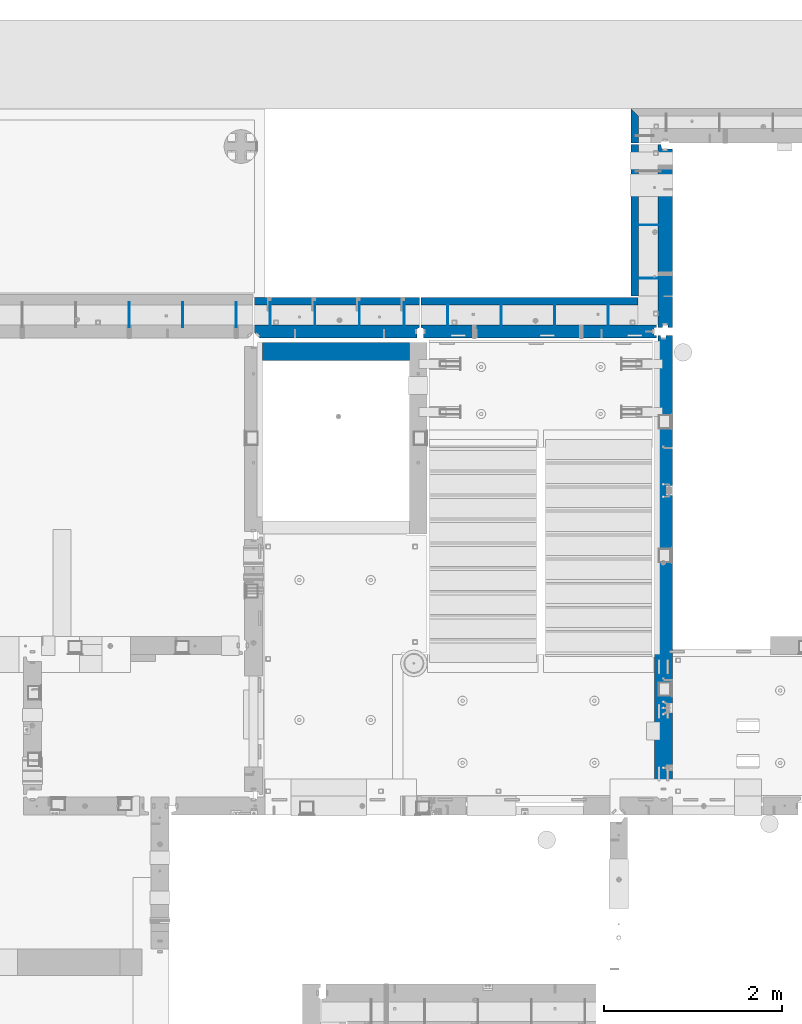
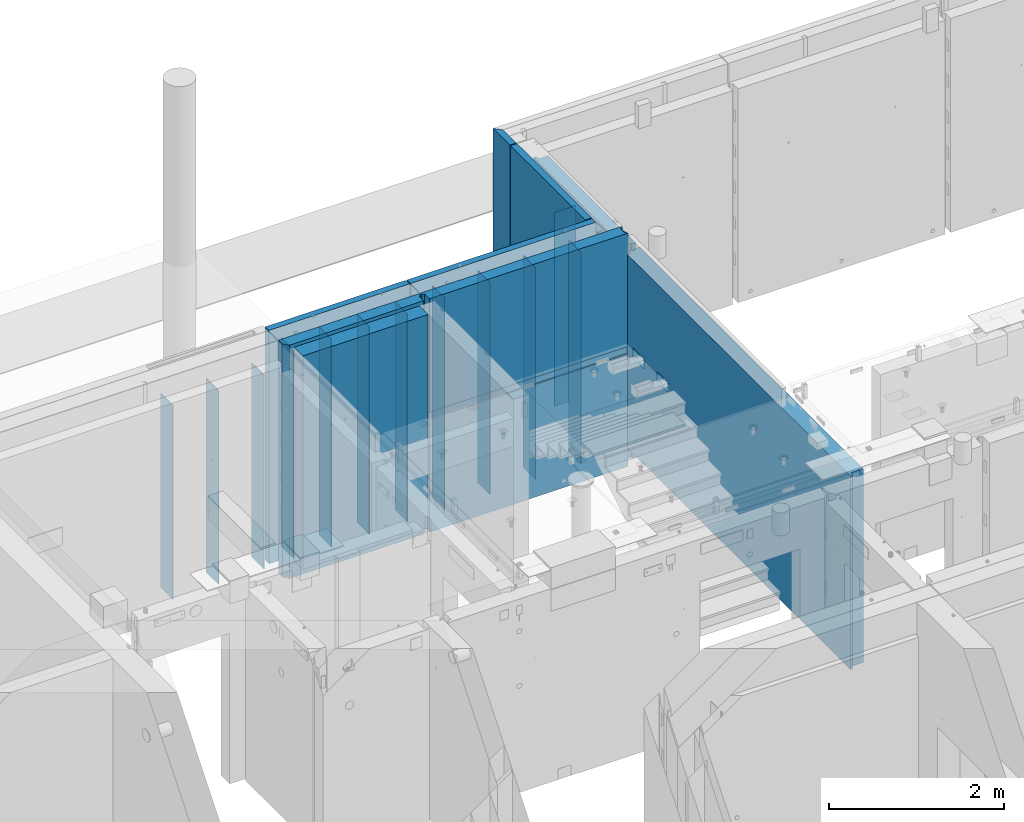
# One storey, part 176 of 264: 22 walls, 7 elements without a shape of their own.
"""IFC2X3 building model written with IfcOpenShell, lengths in millimetres."""

from ifc_helpers import new_model, si_unit, frame, origin_with_axes, place, context, subcontext, project, spatial, faceted_brep, material, type_object, element, aggregate, save


model = new_model("IFC2X3")

# Units and contexts
model_context = context("Model", 3, precision=1e-05, world=origin_with_axes())
body_context = subcontext(model_context, "Body", "Model", "MODEL_VIEW")
ifc_project = project(units=[si_unit("LENGTHUNIT", "METRE", prefix="MILLI"), si_unit("AREAUNIT", "SQUARE_METRE"), si_unit("VOLUMEUNIT", "CUBIC_METRE"), si_unit("MASSUNIT", "GRAM", prefix="KILO"), si_unit("TIMEUNIT", "SECOND"), si_unit("PLANEANGLEUNIT", "RADIAN"), si_unit("SOLIDANGLEUNIT", "STERADIAN"), si_unit("THERMODYNAMICTEMPERATUREUNIT", "DEGREE_CELSIUS"), si_unit("LUMINOUSINTENSITYUNIT", "LUMEN")], contexts=[model_context])

# Site, building, storey
site_placement = place(None, origin_with_axes())
site = spatial("IfcSite", under=ifc_project, at=site_placement, CompositionType="ELEMENT")
building_placement = place(site_placement, origin_with_axes())
building = spatial("IfcBuilding", under=site, at=building_placement, CompositionType="ELEMENT")
storey_placement = place(building_placement, origin_with_axes())
storey = spatial("IfcBuildingStorey", under=building, at=storey_placement, Name="K", CompositionType="ELEMENT", Elevation=0.0)

# Assembly, wall
assembly_1_placement = place(storey_placement, origin_with_axes())
assembly_1 = element("IfcElementAssembly", 1, at=assembly_1_placement, inside=storey, AssemblyPlace="NOTDEFINED", PredefinedType="REINFORCEMENT_UNIT")
ifc_material_1 = material(Name="CONCRETE/C25/30")
wall_type_1 = type_object("IfcWallType", PredefinedType="NOTDEFINED")
wall_1_placement = place(assembly_1_placement, frame((17809.9999105288, 20280.0000293051, 80242.5), z_axis=(0.0, 0.0, 1.0), x_axis=(1.0, 0.0, 0.0)))
wall_1 = element("IfcWall", 2, at=wall_1_placement, type_object=wall_type_1, material=ifc_material_1, context=body_context, shape_type="Brep", body=[
    faceted_brep([(0.0, 100.0, -1487.5), (0.0, 100.0, 1487.5), (1649.99977111816, 100.0, 1487.5), (1649.99977111816, 100.0, -1487.5), (0.0, -100.0, 1487.5), (1649.99977111816, -100.0, 1487.5), (0.0, -100.0, -1487.5), (1649.99977111816, -100.0, -1487.5)], [[[0, 1, 2, 3]], [[1, 4, 5, 2]], [[4, 6, 7, 5]], [[6, 0, 3, 7]], [[5, 7, 3, 2]], [[6, 4, 1, 0]]]),
])
aggregate(assembly_1, [wall_1])

# Assembly, walls
assembly_2_placement = place(storey_placement, origin_with_axes())
assembly_2 = element("IfcElementAssembly", 3, at=assembly_2_placement, inside=storey, AssemblyPlace="NOTDEFINED", PredefinedType="REINFORCEMENT_UNIT")
ifc_material_2 = material(Name="Undefined")
wall_type_2 = type_object("IfcWallType", PredefinedType="NOTDEFINED")
wall_2_placement = place(assembly_2_placement, frame((22280.0033032291, 21699.9956621903, 79990.0), z_axis=(0.0, 0.0, 1.0), x_axis=(-1.0, 3.00000001838171e-08, 0.0)))
wall_2 = element("IfcWall", 4, at=wall_2_placement, type_object=wall_type_2, material=ifc_material_2, Name="(PD)", context=body_context, shape_type="Brep", body=[
    faceted_brep([(0.0, 5.0, -1350.0), (0.0, 5.0, 1350.0), (280.0, 5.0, 1350.0), (280.0, 5.0, -1350.0), (0.0, -5.0, 1350.0), (280.0, -5.0, 1350.0), (0.0, -5.0, -1350.0), (280.0, -5.0, -1350.0)], [[[0, 1, 2, 3]], [[1, 4, 5, 2]], [[4, 6, 7, 5]], [[6, 0, 3, 7]], [[5, 7, 3, 2]], [[6, 4, 1, 0]]]),
])
wall_3_placement = place(assembly_2_placement, frame((22280.0033032291, 21099.9956621903, 79990.0), z_axis=(0.0, 0.0, 1.0), x_axis=(-1.0, 3.00000001838171e-08, 0.0)))
wall_3 = element("IfcWall", 5, at=wall_3_placement, type_object=wall_type_2, material=ifc_material_2, Name="(PD)", context=body_context, shape_type="Brep", body=[
    faceted_brep([(0.0, 5.0, -1350.0), (0.0, 5.0, 1350.0), (280.0, 5.0, 1350.0), (280.0, 5.0, -1350.0), (0.0, -5.0, 1350.0), (280.0, -5.0, 1350.0), (0.0, -5.0, -1350.0), (280.0, -5.0, -1350.0)], [[[0, 1, 2, 3]], [[1, 4, 5, 2]], [[4, 6, 7, 5]], [[6, 0, 3, 7]], [[5, 7, 3, 2]], [[6, 4, 1, 0]]]),
])

assembly_3_placement = place(storey_placement, origin_with_axes())
assembly_3 = element("IfcElementAssembly", 6, at=assembly_3_placement, inside=storey, AssemblyPlace="NOTDEFINED", PredefinedType="REINFORCEMENT_UNIT")
wall_4_placement = place(assembly_3_placement, frame((17515.0002441406, 20549.9951872276, 79990.0), z_axis=(0.0, 0.0, 1.0), x_axis=(0.0, 1.0, 0.0)))
wall_4 = element("IfcWall", 7, at=wall_4_placement, type_object=wall_type_2, material=ifc_material_2, Name="(PD)", context=body_context, shape_type="Brep", body=[
    faceted_brep([(0.0, 5.0, -1350.0), (0.0, 5.0, 1350.0), (280.0, 5.0, 1350.0), (280.0, 5.0, -1350.0), (0.0, -5.0, 1350.0), (280.0, -5.0, 1350.0), (0.0, -5.0, -1350.0), (280.0, -5.0, -1350.0)], [[[0, 1, 2, 3]], [[1, 4, 5, 2]], [[4, 6, 7, 5]], [[6, 0, 3, 7]], [[5, 7, 3, 2]], [[6, 4, 1, 0]]]),
])
wall_5_placement = place(assembly_3_placement, frame((16915.0002441406, 20549.9951872276, 79990.0), z_axis=(0.0, 0.0, 1.0), x_axis=(0.0, 1.0, 0.0)))
wall_5 = element("IfcWall", 8, at=wall_5_placement, type_object=wall_type_2, material=ifc_material_2, Name="(PD)", context=body_context, shape_type="Brep", body=[
    faceted_brep([(0.0, 5.0, -1350.0), (0.0, 5.0, 1350.0), (280.0, 5.0, 1350.0), (280.0, 5.0, -1350.0), (0.0, -5.0, 1350.0), (280.0, -5.0, 1350.0), (0.0, -5.0, -1350.0), (280.0, -5.0, -1350.0)], [[[0, 1, 2, 3]], [[1, 4, 5, 2]], [[4, 6, 7, 5]], [[6, 0, 3, 7]], [[5, 7, 3, 2]], [[6, 4, 1, 0]]]),
])
wall_6_placement = place(assembly_3_placement, frame((16315.0002441406, 20549.9951872276, 79990.0), z_axis=(0.0, 0.0, 1.0), x_axis=(0.0, 1.0, 0.0)))
wall_6 = element("IfcWall", 9, at=wall_6_placement, type_object=wall_type_2, material=ifc_material_2, Name="(PD)", context=body_context, shape_type="Brep", body=[
    faceted_brep([(0.0, 5.0, -1350.0), (0.0, 5.0, 1350.0), (280.0, 5.0, 1350.0), (280.0, 5.0, -1350.0), (0.0, -5.0, 1350.0), (280.0, -5.0, 1350.0), (0.0, -5.0, -1350.0), (280.0, -5.0, -1350.0)], [[[0, 1, 2, 3]], [[1, 4, 5, 2]], [[4, 6, 7, 5]], [[6, 0, 3, 7]], [[5, 7, 3, 2]], [[6, 4, 1, 0]]]),
])
aggregate(assembly_3, [wall_4, wall_5, wall_6])

assembly_4_placement = place(storey_placement, origin_with_axes())
assembly_4 = element("IfcElementAssembly", 10, at=assembly_4_placement, inside=storey, AssemblyPlace="NOTDEFINED", PredefinedType="REINFORCEMENT_UNIT")
wall_type_3 = type_object("IfcWallType", PredefinedType="NOTDEFINED")
wall_7_placement = place(assembly_4_placement, frame((21690.0002441406, 20549.9951872276, 80115.0), z_axis=(0.0, 0.0, 1.0), x_axis=(0.0, 1.0, 0.0)))
wall_7 = element("IfcWall", 11, at=wall_7_placement, type_object=wall_type_3, material=ifc_material_2, Name="(PD)", context=body_context, shape_type="Brep", body=[
    faceted_brep([(0.0, 5.0, -1475.0), (0.0, 5.0, 1475.0), (280.0, 5.0, 1475.0), (280.0, 5.0, -1475.0), (0.0, -5.0, 1475.0), (280.0, -5.0, 1475.0), (0.0, -5.0, -1475.0), (280.0, -5.0, -1475.0)], [[[0, 1, 2, 3]], [[1, 4, 5, 2]], [[4, 6, 7, 5]], [[6, 0, 3, 7]], [[5, 7, 3, 2]], [[6, 4, 1, 0]]]),
])
wall_8_placement = place(assembly_4_placement, frame((21090.0002441406, 20549.9951872276, 80115.0), z_axis=(0.0, 0.0, 1.0), x_axis=(0.0, 1.0, 0.0)))
wall_8 = element("IfcWall", 12, at=wall_8_placement, type_object=wall_type_3, material=ifc_material_2, Name="(PD)", context=body_context, shape_type="Brep", body=[
    faceted_brep([(0.0, 5.0, -1475.0), (0.0, 5.0, 1475.0), (280.0, 5.0, 1475.0), (280.0, 5.0, -1475.0), (0.0, -5.0, 1475.0), (280.0, -5.0, 1475.0), (0.0, -5.0, -1475.0), (280.0, -5.0, -1475.0)], [[[0, 1, 2, 3]], [[1, 4, 5, 2]], [[4, 6, 7, 5]], [[6, 0, 3, 7]], [[5, 7, 3, 2]], [[6, 4, 1, 0]]]),
])
wall_9_placement = place(assembly_4_placement, frame((20490.0002441406, 20549.9951872276, 80115.0), z_axis=(0.0, 0.0, 1.0), x_axis=(0.0, 1.0, 0.0)))
wall_9 = element("IfcWall", 13, at=wall_9_placement, type_object=wall_type_3, material=ifc_material_2, Name="(PD)", context=body_context, shape_type="Brep", body=[
    faceted_brep([(0.0, 5.0, -1475.0), (0.0, 5.0, 1475.0), (280.0, 5.0, 1475.0), (280.0, 5.0, -1475.0), (0.0, -5.0, 1475.0), (280.0, -5.0, 1475.0), (0.0, -5.0, -1475.0), (280.0, -5.0, -1475.0)], [[[0, 1, 2, 3]], [[1, 4, 5, 2]], [[4, 6, 7, 5]], [[6, 0, 3, 7]], [[5, 7, 3, 2]], [[6, 4, 1, 0]]]),
])
wall_10_placement = place(assembly_4_placement, frame((19890.0002441406, 20549.9951872276, 80115.0), z_axis=(0.0, 0.0, 1.0), x_axis=(0.0, 1.0, 0.0)))
wall_10 = element("IfcWall", 14, at=wall_10_placement, type_object=wall_type_3, material=ifc_material_2, Name="(PD)", context=body_context, shape_type="Brep", body=[
    faceted_brep([(0.0, 5.0, -1475.0), (0.0, 5.0, 1475.0), (280.0, 5.0, 1475.0), (280.0, 5.0, -1475.0), (0.0, -5.0, 1475.0), (280.0, -5.0, 1475.0), (0.0, -5.0, -1475.0), (280.0, -5.0, -1475.0)], [[[0, 1, 2, 3]], [[1, 4, 5, 2]], [[4, 6, 7, 5]], [[6, 0, 3, 7]], [[5, 7, 3, 2]], [[6, 4, 1, 0]]]),
])

assembly_5_placement = place(storey_placement, origin_with_axes())
assembly_5 = element("IfcElementAssembly", 15, at=assembly_5_placement, inside=storey, AssemblyPlace="NOTDEFINED", PredefinedType="REINFORCEMENT_UNIT")
wall_type_4 = type_object("IfcWallType", PredefinedType="NOTDEFINED")
wall_11_placement = place(assembly_5_placement, frame((19400.0002441406, 20549.9951872276, 80090.0), z_axis=(0.0, 0.0, 1.0), x_axis=(0.0, 1.0, 0.0)))
wall_11 = element("IfcWall", 16, at=wall_11_placement, type_object=wall_type_4, material=ifc_material_2, Name="(PD)", context=body_context, shape_type="Brep", body=[
    faceted_brep([(0.0, 5.0, -1450.0), (0.0, 5.0, 1450.0), (280.0, 5.0, 1450.0), (280.0, 5.0, -1450.0), (0.0, -5.0, 1450.0), (280.0, -5.0, 1450.0), (0.0, -5.0, -1450.0), (280.0, -5.0, -1450.0)], [[[0, 1, 2, 3]], [[1, 4, 5, 2]], [[4, 6, 7, 5]], [[6, 0, 3, 7]], [[5, 7, 3, 2]], [[6, 4, 1, 0]]]),
])
wall_12_placement = place(assembly_5_placement, frame((18900.0002441406, 20549.9951872276, 80090.0), z_axis=(0.0, 0.0, 1.0), x_axis=(0.0, 1.0, 0.0)))
wall_12 = element("IfcWall", 17, at=wall_12_placement, type_object=wall_type_4, material=ifc_material_2, Name="(PD)", context=body_context, shape_type="Brep", body=[
    faceted_brep([(0.0, 5.0, -1450.0), (0.0, 5.0, 1450.0), (280.0, 5.0, 1450.0), (280.0, 5.0, -1450.0), (0.0, -5.0, 1450.0), (280.0, -5.0, 1450.0), (0.0, -5.0, -1450.0), (280.0, -5.0, -1450.0)], [[[0, 1, 2, 3]], [[1, 4, 5, 2]], [[4, 6, 7, 5]], [[6, 0, 3, 7]], [[5, 7, 3, 2]], [[6, 4, 1, 0]]]),
])
wall_13_placement = place(assembly_5_placement, frame((18400.0002441406, 20549.9951872276, 80090.0), z_axis=(0.0, 0.0, 1.0), x_axis=(0.0, 1.0, 0.0)))
wall_13 = element("IfcWall", 18, at=wall_13_placement, type_object=wall_type_4, material=ifc_material_2, Name="(PD)", context=body_context, shape_type="Brep", body=[
    faceted_brep([(0.0, 5.0, -1450.0), (0.0, 5.0, 1450.0), (280.0, 5.0, 1450.0), (280.0, 5.0, -1450.0), (0.0, -5.0, 1450.0), (280.0, -5.0, 1450.0), (0.0, -5.0, -1450.0), (280.0, -5.0, -1450.0)], [[[0, 1, 2, 3]], [[1, 4, 5, 2]], [[4, 6, 7, 5]], [[6, 0, 3, 7]], [[5, 7, 3, 2]], [[6, 4, 1, 0]]]),
])
wall_14_placement = place(assembly_5_placement, frame((17900.0002441406, 20549.9951872276, 80110.0), z_axis=(0.0, 0.0, 1.0), x_axis=(0.0, 1.0, 0.0)))
wall_14 = element("IfcWall", 19, at=wall_14_placement, type_object=wall_type_4, material=ifc_material_2, Name="(PD)", context=body_context, shape_type="Brep", body=[
    faceted_brep([(0.0, 5.0, -1450.0), (0.0, 5.0, 1450.0), (280.0, 5.0, 1450.0), (280.0, 5.0, -1450.0), (0.0, -5.0, 1450.0), (280.0, -5.0, 1450.0), (0.0, -5.0, -1450.0), (280.0, -5.0, -1450.0)], [[[0, 1, 2, 3]], [[1, 4, 5, 2]], [[4, 6, 7, 5]], [[6, 0, 3, 7]], [[5, 7, 3, 2]], [[6, 4, 1, 0]]]),
])

# Assembly, wall
assembly_6_placement = place(storey_placement, origin_with_axes())
assembly_6 = element("IfcElementAssembly", 20, at=assembly_6_placement, inside=storey, AssemblyPlace="NOTDEFINED", PredefinedType="REINFORCEMENT_UNIT")
ifc_material_3 = material(Name="CONCRETE/C30/37")
wall_type_5 = type_object("IfcWallType", PredefinedType="NOTDEFINED")
wall_15_placement = place(assembly_6_placement, frame((21987.4994055291, 23005.0, 80115.0), z_axis=(0.0, 0.0, 1.0), x_axis=(0.0, -1.0, 0.0)))
wall_15 = element("IfcWall", 21, at=wall_15_placement, type_object=wall_type_5, material=ifc_material_3, context=body_context, shape_type="Brep", body=[
    faceted_brep([(385.0, -42.5, 1625.0), (385.0, -42.5, -1625.0), (385.0, 42.5, -1625.0), (385.0, 42.5, 1625.0), (85.0, 42.5, 1625.0), (3.63797880709171e-12, -42.4999999999964, 1625.0), (3.63797880709171e-12, -42.4999999999964, -1625.0), (85.0, 42.5, -1625.0)], [[[0, 1, 2, 3]], [[0, 3, 4, 5]], [[1, 0, 5, 6]], [[2, 1, 6, 7]], [[3, 2, 7, 4]], [[6, 5, 4, 7]]]),
])
aggregate(assembly_6, [wall_15])

# Wall
wall_16_placement = place(assembly_2_placement, frame((21987.4994055291, 20899.9994219008, 80115.0), z_axis=(0.0, 0.0, 1.0), x_axis=(0.0, 1.0, 0.0)))
wall_16 = element("IfcWall", 22, at=wall_16_placement, type_object=wall_type_5, material=ifc_material_3, context=body_context, shape_type="Brep", body=[
    faceted_brep([(1366.8658789863, -42.5, -742.815116744532), (1366.8658789863, 42.5, -742.815116744532), (1357.62099845137, 42.5, -769.235467389692), (1357.62099845137, -42.5, -769.235467389692), (1342.72882527207, 42.5, -792.936225232348), (1342.72882527207, -42.5, -792.936225232348), (1322.93611519591, 42.5, -812.728935308507), (1322.93611519591, -42.5, -812.728935308507), (1299.23535735326, 42.5, -827.621108487801), (1299.23535735326, -42.5, -827.621108487801), (1272.81500670811, 42.5, -836.865989022728), (1272.81500670811, -42.5, -836.865989022728), (1244.99988996357, 42.5, -840.0), (1244.99988996357, -42.5, -840.0), (1217.18477321903, 42.5, -836.865989022728), (1217.18477321903, -42.5, -836.865989022728), (1190.76442257387, 42.5, -827.621108487801), (1190.76442257387, -42.5, -827.621108487801), (1167.06366473123, 42.5, -812.728935308507), (1167.06366473123, -42.5, -812.728935308507), (1147.27095465507, 42.5, -792.936225232348), (1147.27095465507, -42.5, -792.936225232348), (1132.37878147577, 42.5, -769.235467389692), (1132.37878147577, -42.5, -769.235467389692), (1123.13390094084, 42.5, -742.815116744532), (1123.13390094084, -42.5, -742.815116744532), (1119.99988996357, 42.5, -715.0), (1119.99988996357, -42.5, -715.0), (1123.13390094084, 42.5, -687.184883255468), (1123.13390094084, -42.5, -687.184883255468), (1132.37878147577, 42.5, -660.764532610308), (1132.37878147577, -42.5, -660.764532610308), (1147.27095465507, 42.5, -637.063774767652), (1147.27095465507, -42.5, -637.063774767652), (1167.06366473123, 42.5, -617.271064691493), (1167.06366473123, -42.5, -617.271064691493), (1190.76442257387, 42.5, -602.378891512199), (1190.76442257387, -42.5, -602.378891512199), (1217.18477321903, 42.5, -593.134010977272), (1217.18477321903, -42.5, -593.134010977272), (1244.99988996357, 42.5, -590.0), (1244.99988996357, -42.5, -590.0), (1272.81500670811, 42.5, -593.134010977272), (1272.81500670811, -42.5, -593.134010977272), (1299.23535735326, 42.5, -602.378891512199), (1299.23535735326, -42.5, -602.378891512199), (1322.93611519591, 42.5, -617.271064691493), (1322.93611519591, -42.5, -617.271064691493), (1342.72882527207, 42.5, -637.063774767652), (1342.72882527207, -42.5, -637.063774767652), (1357.62099845137, 42.5, -660.764532610308), (1357.62099845137, -42.5, -660.764532610308), (1366.8658789863, 42.5, -687.184883255468), (1366.8658789863, -42.5, -687.184883255468), (1369.99988996357, 42.5, -715.0), (1369.99988996357, -42.5, -715.0), (0.0, 42.5000000000036, 1625.0), (3.63797880709171e-12, -42.4999999999964, 1625.0), (1705.00057809919, -42.5, 1625.0), (1705.00057809919, 42.5, 1625.0), (3.63797880709171e-12, -42.4999999999964, -1625.0), (0.0, 42.5000000000036, -1625.0), (1705.00057809919, 42.5, -1625.0), (1705.00057809919, -42.5, -1625.0), (1606.60395622092, -42.5, -765.0), (1590.71209396113, -42.5, -785.710678118659), (1570.00141584247, -42.5, -801.602540378444), (1545.88332035273, -42.5, -811.592582628902), (1520.00141584247, -42.5, -815.0), (1494.11951133222, -42.5, -811.592582628902), (1470.00141584247, -42.5, -801.602540378444), (1449.29073772382, -42.5, -785.710678118659), (1433.39887546403, -42.5, -765.0), (1423.40883321357, -42.5, -740.881904510257), (1420.00141584247, -42.5, -715.0), (1423.40883321357, -42.5, -689.118095489743), (1433.39887546403, -42.5, -665.0), (1449.29073772382, -42.5, -644.289321881341), (1470.00141584247, -42.5, -628.397459621556), (1494.11951133222, -42.5, -618.407417371098), (1520.00141584247, -42.5, -615.0), (1545.88332035273, -42.5, -618.407417371098), (1570.00141584247, -42.5, -628.397459621556), (1590.71209396113, -42.5, -644.289321881341), (1606.60395622092, -42.5, -665.0), (1616.59399847138, -42.5, -689.118095489743), (1620.00141584247, -42.5, -715.0), (1616.59399847138, -42.5, -740.881904510257), (1606.60395622092, 42.5, -665.0), (1616.59399847138, 42.5, -689.118095489743), (1590.71209396113, 42.5, -644.289321881341), (1570.00141584247, 42.5, -628.397459621556), (1545.88332035273, 42.5, -618.407417371098), (1520.00141584247, 42.5, -615.0), (1494.11951133222, 42.5, -618.407417371098), (1470.00141584247, 42.5, -628.397459621556), (1449.29073772382, 42.5, -644.289321881341), (1433.39887546403, 42.5, -665.0), (1423.40883321357, 42.5, -689.118095489743), (1420.00141584247, 42.5, -715.0), (1423.40883321357, 42.5, -740.881904510257), (1433.39887546403, 42.5, -765.0), (1449.29073772382, 42.5, -785.710678118659), (1470.00141584247, 42.5, -801.602540378444), (1494.11951133222, 42.5, -811.592582628902), (1520.00141584247, 42.5, -815.0), (1545.88332035273, 42.5, -811.592582628902), (1570.00141584247, 42.5, -801.602540378444), (1590.71209396113, 42.5, -785.710678118659), (1606.60395622092, 42.5, -765.0), (1616.59399847138, 42.5, -740.881904510257), (1620.00141584247, 42.5, -715.0)], [[[0, 1, 2, 3]], [[3, 2, 4, 5]], [[5, 4, 6, 7]], [[7, 6, 8, 9]], [[9, 8, 10, 11]], [[11, 10, 12, 13]], [[13, 12, 14, 15]], [[15, 14, 16, 17]], [[17, 16, 18, 19]], [[19, 18, 20, 21]], [[21, 20, 22, 23]], [[23, 22, 24, 25]], [[25, 24, 26, 27]], [[27, 26, 28, 29]], [[29, 28, 30, 31]], [[31, 30, 32, 33]], [[33, 32, 34, 35]], [[35, 34, 36, 37]], [[37, 36, 38, 39]], [[39, 38, 40, 41]], [[41, 40, 42, 43]], [[43, 42, 44, 45]], [[45, 44, 46, 47]], [[47, 46, 48, 49]], [[49, 48, 50, 51]], [[51, 50, 52, 53]], [[53, 52, 54, 55]], [[55, 54, 1, 0]], [[56, 57, 58, 59]], [[60, 57, 56, 61]], [[60, 61, 62, 63]], [[58, 63, 62, 59]], [[57, 60, 63, 58], [3, 5, 7, 9, 11, 13, 15, 17, 19, 21, 23, 25, 27, 29, 31, 33, 35, 37, 39, 41, 43, 45, 47, 49, 51, 53, 55, 0], [64, 65, 66, 67, 68, 69, 70, 71, 72, 73, 74, 75, 76, 77, 78, 79, 80, 81, 82, 83, 84, 85, 86, 87]], [[84, 88, 89, 85]], [[83, 90, 88, 84]], [[82, 91, 90, 83]], [[81, 92, 91, 82]], [[80, 93, 92, 81]], [[79, 94, 93, 80]], [[78, 95, 94, 79]], [[77, 96, 95, 78]], [[76, 97, 96, 77]], [[75, 98, 97, 76]], [[74, 99, 98, 75]], [[73, 100, 99, 74]], [[72, 101, 100, 73]], [[71, 102, 101, 72]], [[70, 103, 102, 71]], [[69, 104, 103, 70]], [[68, 105, 104, 69]], [[67, 106, 105, 68]], [[66, 107, 106, 67]], [[65, 108, 107, 66]], [[64, 109, 108, 65]], [[87, 110, 109, 64]], [[86, 111, 110, 87]], [[85, 89, 111, 86]], [[61, 56, 59, 62], [50, 48, 46, 44, 42, 40, 38, 36, 34, 32, 30, 28, 26, 24, 22, 20, 18, 16, 14, 12, 10, 8, 6, 4, 2, 1, 54, 52], [88, 90, 91, 92, 93, 94, 95, 96, 97, 98, 99, 100, 101, 102, 103, 104, 105, 106, 107, 108, 109, 110, 111, 89]]]),
])

wall_17_placement = place(assembly_4_placement, frame((19590.0015743464, 20842.5000000028, 80115.0), z_axis=(0.0, 0.0, 1.0), x_axis=(1.0, 0.0, 0.0)))
wall_17 = element("IfcWall", 23, at=wall_17_placement, type_object=wall_type_5, material=ifc_material_3, context=body_context, shape_type="Brep", body=[
    faceted_brep([(0.0, 42.5000000000036, -1625.0), (0.0, 42.5000000000036, 1625.0), (2434.99931653097, 42.4999999999964, 1625.0), (2434.99931653097, 42.4999999999964, -1625.0), (3.63797880709171e-12, -42.4999999999964, 1625.0), (2434.99931653097, -42.5000000000036, 1625.0), (3.63797880709171e-12, -42.4999999999964, -1625.0), (2434.99931653097, -42.5000000000036, -1625.0)], [[[0, 1, 2, 3]], [[1, 4, 5, 2]], [[4, 6, 7, 5]], [[6, 0, 3, 7]], [[5, 7, 3, 2]], [[6, 4, 1, 0]]]),
])

wall_18_placement = place(assembly_5_placement, frame((17720.0001611861, 20842.4999938629, 80115.0), z_axis=(0.0, 0.0, 1.0), x_axis=(1.0, 0.0, 0.0)))
wall_18 = element("IfcWall", 24, at=wall_18_placement, type_object=wall_type_5, material=ifc_material_3, context=body_context, shape_type="Brep", body=[
    faceted_brep([(-0.000187281060789246, 42.5000000000036, -1625.0), (-0.000187281060789246, 42.5000000000036, 1625.0), (1855.00146334826, 42.5000000000036, 1625.0), (1855.00146334826, 42.5000000000036, -1625.0), (-0.000135091060656123, -42.4999999999964, 1625.0), (1855.00146334826, -42.4999999999964, 1625.0), (-0.000135091060656123, -42.4999999999964, -1625.0), (1855.00146334826, -42.4999999999964, -1625.0)], [[[0, 1, 2, 3]], [[1, 4, 5, 2]], [[4, 6, 7, 5]], [[6, 0, 3, 7]], [[5, 7, 3, 2]], [[6, 4, 1, 0]]]),
])

wall_type_6 = type_object("IfcWallType", PredefinedType="NOTDEFINED")
wall_19_placement = place(assembly_2_placement, frame((22329.9994055291, 20579.9988438016, 79980.0), z_axis=(0.0, 0.0, 1.0), x_axis=(0.0, 1.0, 0.0)))
wall_19 = element("IfcWall", 25, at=wall_19_placement, type_object=wall_type_6, material=ifc_material_1, context=body_context, shape_type="Brep", body=[
    faceted_brep([(1936.59457657057, -80.0012033323073, -605.881904510257), (1936.59457657057, 80.0, -605.881904510257), (1926.60453432011, 80.0, -630.0), (1926.60453432011, -80.0012033323073, -630.0), (1910.71267206032, 80.0, -650.710678118659), (1910.71267206032, -80.0012033323073, -650.710678118659), (1890.00199394167, 80.0, -666.602540378444), (1890.00199394167, -80.0012033323073, -666.602540378444), (1865.88389845192, 80.0, -676.592582628902), (1865.88389845192, -80.0012033323073, -676.592582628902), (1840.00199394167, 80.0, -680.0), (1840.00199394167, -80.0012033323073, -680.0), (1814.12008943141, 80.0, -676.592582628902), (1814.12008943141, -80.0012033323073, -676.592582628902), (1790.00199394167, 80.0, -666.602540378444), (1790.00199394167, -80.0012033323073, -666.602540378444), (1769.29131582301, 80.0, -650.710678118659), (1769.29131582301, -80.0012033323073, -650.710678118659), (1753.39945356322, 80.0, -630.0), (1753.39945356322, -80.0012033323073, -630.0), (1743.40941131276, 80.0, -605.881904510257), (1743.40941131276, -80.0012033323073, -605.881904510257), (1740.00199394167, 80.0, -580.0), (1740.00199394167, -80.0012033323073, -580.0), (1743.40941131276, 80.0, -554.118095489743), (1743.40941131276, -80.0012033323073, -554.118095489743), (1753.39945356322, 80.0, -530.0), (1753.39945356322, -80.0012033323073, -530.0), (1769.29131582301, 80.0, -509.289321881341), (1769.29131582301, -80.0012033323073, -509.289321881341), (1790.00199394167, 80.0, -493.397459621556), (1790.00199394167, -80.0012033323073, -493.397459621556), (1814.12008943141, 80.0, -483.407417371098), (1814.12008943141, -80.0012033323073, -483.407417371098), (1840.00199394167, 80.0, -480.0), (1840.00199394167, -80.0012033323073, -480.0), (1865.88389845192, 80.0, -483.407417371098), (1865.88389845192, -80.0012033323073, -483.407417371098), (1890.00199394167, 80.0, -493.397459621556), (1890.00199394167, -80.0012033323073, -493.397459621556), (1910.71267206032, 80.0, -509.289321881341), (1910.71267206032, -80.0012033323073, -509.289321881341), (1926.60453432011, 80.0, -530.0), (1926.60453432011, -80.0012033323073, -530.0), (1936.59457657057, 80.0, -554.118095489743), (1936.59457657057, -80.0012033323073, -554.118095489743), (1940.00199394167, 80.0, -580.0), (1940.00199394167, -80.0012033323073, -580.0), (-4.99942190080765, 29.999405529139, 1490.0), (-4.99942190080765, 29.999405529139, -1265.0), (-4.99942190080765, -30.000594470861, -1265.0), (-4.99942190080765, -30.000594470861, 1490.0), (-29.9994219008076, 29.999405529139, 1490.0), (-29.9994219008076, 29.999405529139, -1265.0), (-29.9994219008076, 80.0, 1490.0), (-29.9994219008076, 80.0, -1490.0), (-29.9994219008076, 29.999405529139, -1490.0), (-4.99942190080765, 29.999405529139, -1490.0), (-4.99942190080765, -30.000594470861, -1490.0), (2025.00115619838, 80.0, -1490.0), (2025.00115619838, 50.0000000000036, -1490.0), (1975.00115619838, 37.0, -1490.0), (1975.00115619838, -80.0, -1490.0), (-29.9994219008076, -80.0, -1490.0), (-29.9994219008076, -30.000594470861, -1490.0), (-29.9994219008076, -30.000594470861, -1265.0), (-29.9994219008076, -80.0, 1490.0), (-29.9994219008076, -30.000594470861, 1490.0), (1975.00115619838, -80.0, 1490.0), (1975.00115619838, 37.0, 1490.0), (2025.00115619838, 50.0000000000036, 1490.0), (2025.00115619838, 80.0, 1490.0), (1677.62157655056, -80.0012033323073, -634.235467389692), (1662.72940337126, -80.0012033323073, -657.936225232348), (1642.9366932951, -80.0012033323073, -677.728935308507), (1619.23593545246, -80.0012033323073, -692.621108487801), (1592.8155848073, -80.0012033323073, -701.865989022728), (1565.00046806276, -80.0012033323073, -705.0), (1537.18535131822, -80.0012033323073, -701.865989022728), (1510.76500067307, -80.0012033323073, -692.621108487801), (1487.06424283042, -80.0012033323073, -677.728935308507), (1467.27153275426, -80.0012033323073, -657.936225232348), (1452.37935957496, -80.0012033323073, -634.235467389692), (1443.13447904003, -80.0012033323073, -607.815116744532), (1440.00046806276, -80.0012033323073, -580.0), (1443.13447904003, -80.0012033323073, -552.184883255468), (1452.37935957496, -80.0012033323073, -525.764532610308), (1467.27153275426, -80.0012033323073, -502.063774767652), (1487.06424283042, -80.0012033323073, -482.271064691493), (1510.76500067307, -80.0012033323073, -467.378891512199), (1537.18535131822, -80.0012033323073, -458.134010977272), (1565.00046806276, -80.0012033323073, -455.0), (1592.8155848073, -80.0012033323073, -458.134010977272), (1619.23593545246, -80.0012033323073, -467.378891512199), (1642.9366932951, -80.0012033323073, -482.271064691493), (1662.72940337126, -80.0012033323073, -502.063774767652), (1677.62157655056, -80.0012033323073, -525.764532610308), (1686.86645708549, -80.0012033323073, -552.184883255468), (1690.00046806276, -80.0012033323073, -580.0), (1686.86645708549, -80.0012033323073, -607.815116744532), (1677.62157655056, 80.0, -525.764532610308), (1686.86645708549, 80.0, -552.184883255468), (1662.72940337126, 80.0, -502.063774767652), (1642.9366932951, 80.0, -482.271064691493), (1619.23593545246, 80.0, -467.378891512199), (1592.8155848073, 80.0, -458.134010977272), (1565.00046806276, 80.0, -455.0), (1537.18535131822, 80.0, -458.134010977272), (1510.76500067307, 80.0, -467.378891512199), (1487.06424283042, 80.0, -482.271064691493), (1467.27153275426, 80.0, -502.063774767652), (1452.37935957496, 80.0, -525.764532610308), (1443.13447904003, 80.0, -552.184883255468), (1440.00046806276, 80.0, -580.0), (1443.13447904003, 80.0, -607.815116744532), (1452.37935957496, 80.0, -634.235467389692), (1467.27153275426, 80.0, -657.936225232348), (1487.06424283042, 80.0, -677.728935308507), (1510.76500067307, 80.0, -692.621108487801), (1537.18535131822, 80.0, -701.865989022728), (1565.00046806276, 80.0, -705.0), (1592.8155848073, 80.0, -701.865989022728), (1619.23593545246, 80.0, -692.621108487801), (1642.9366932951, 80.0, -677.728935308507), (1662.72940337126, 80.0, -657.936225232348), (1677.62157655056, 80.0, -634.235467389692), (1686.86645708549, 80.0, -607.815116744532), (1690.00046806276, 80.0, -580.0)], [[[0, 1, 2, 3]], [[3, 2, 4, 5]], [[5, 4, 6, 7]], [[7, 6, 8, 9]], [[9, 8, 10, 11]], [[11, 10, 12, 13]], [[13, 12, 14, 15]], [[15, 14, 16, 17]], [[17, 16, 18, 19]], [[19, 18, 20, 21]], [[21, 20, 22, 23]], [[23, 22, 24, 25]], [[25, 24, 26, 27]], [[27, 26, 28, 29]], [[29, 28, 30, 31]], [[31, 30, 32, 33]], [[33, 32, 34, 35]], [[35, 34, 36, 37]], [[37, 36, 38, 39]], [[39, 38, 40, 41]], [[41, 40, 42, 43]], [[43, 42, 44, 45]], [[45, 44, 46, 47]], [[47, 46, 1, 0]], [[48, 49, 50, 51]], [[52, 53, 49, 48]], [[52, 54, 55, 56, 53]], [[53, 56, 57, 49]], [[49, 57, 58, 50]], [[56, 55, 59, 60, 61, 62, 63, 64, 58, 57]], [[50, 58, 64, 65]], [[63, 66, 67, 65, 64]], [[51, 50, 65, 67]], [[66, 68, 69, 70, 71, 54, 52, 48, 51, 67]], [[59, 71, 70, 60]], [[69, 61, 60, 70]], [[68, 62, 61, 69]], [[66, 63, 62, 68], [3, 5, 7, 9, 11, 13, 15, 17, 19, 21, 23, 25, 27, 29, 31, 33, 35, 37, 39, 41, 43, 45, 47, 0], [72, 73, 74, 75, 76, 77, 78, 79, 80, 81, 82, 83, 84, 85, 86, 87, 88, 89, 90, 91, 92, 93, 94, 95, 96, 97, 98, 99]], [[96, 100, 101, 97]], [[95, 102, 100, 96]], [[94, 103, 102, 95]], [[93, 104, 103, 94]], [[92, 105, 104, 93]], [[91, 106, 105, 92]], [[90, 107, 106, 91]], [[89, 108, 107, 90]], [[88, 109, 108, 89]], [[87, 110, 109, 88]], [[86, 111, 110, 87]], [[85, 112, 111, 86]], [[84, 113, 112, 85]], [[83, 114, 113, 84]], [[82, 115, 114, 83]], [[81, 116, 115, 82]], [[80, 117, 116, 81]], [[79, 118, 117, 80]], [[78, 119, 118, 79]], [[77, 120, 119, 78]], [[76, 121, 120, 77]], [[75, 122, 121, 76]], [[74, 123, 122, 75]], [[73, 124, 123, 74]], [[72, 125, 124, 73]], [[99, 126, 125, 72]], [[98, 127, 126, 99]], [[97, 101, 127, 98]], [[55, 54, 71, 59], [42, 40, 38, 36, 34, 32, 30, 28, 26, 24, 22, 20, 18, 16, 14, 12, 10, 8, 6, 4, 2, 1, 46, 44], [100, 102, 103, 104, 105, 106, 107, 108, 109, 110, 111, 112, 113, 114, 115, 116, 117, 118, 119, 120, 121, 122, 123, 124, 125, 126, 127, 101]]]),
])

aggregate(assembly_2, [wall_2, wall_3, wall_19, wall_16])

# Assembly, wall
assembly_7_placement = place(storey_placement, origin_with_axes())
assembly_7 = element("IfcElementAssembly", 26, at=assembly_7_placement, inside=storey, AssemblyPlace="NOTDEFINED", PredefinedType="REINFORCEMENT_UNIT")
wall_type_7 = type_object("IfcWallType", PredefinedType="NOTDEFINED")
wall_20_placement = place(assembly_7_placement, frame((22310.0, 15280.0, 80122.5), z_axis=(0.0, 0.0, 1.0), x_axis=(0.0, 1.0, 0.0)))
wall_20 = element("IfcWall", 27, at=wall_20_placement, type_object=wall_type_7, material=ifc_material_1, context=body_context, shape_type="Brep", body=[
    faceted_brep([(30.0, 70.0000000000036, 1347.5), (30.0, 70.0000000000036, -1347.5), (80.0, 57.0, -1347.5), (80.0, 57.0, 1347.5), (80.0, -100.0, 1347.5), (80.0, -100.0, -1347.5), (4219.99526788829, 0.0998642726626713, 92.5), (4419.99526788829, 0.0998642726626713, 92.5), (4419.99526788829, 0.0998642726626713, -17.5), (4219.99526788829, 0.0998642726626713, -17.5), (4444.99526788829, 100.099864272663, -17.5), (4444.99526788829, 100.099864272663, 127.5), (4194.99526788829, 100.099864272663, -17.5), (4194.99526788829, 100.099864272663, 127.5), (4759.99526788829, 0.0998642726626713, 92.5), (4959.99526788829, 0.0998642726626713, 92.5), (4959.99526788829, 0.0998642726626713, -17.5), (4759.99526788829, 0.0998642726626713, -17.5), (4984.99526788829, 100.099864272663, -17.5), (4984.99526788829, 100.099864272663, 127.5), (4734.99526788829, 100.099864272663, -17.5), (4734.99526788829, 100.099864272663, 127.5), (30.0, 100.0, -1347.5), (30.0, 100.0, 1347.5), (5120.0, 100.0, 1347.5), (5120.0, 100.0, -1347.5), (5120.0, 59.9999999999345, 1347.5), (5120.0, 59.9999999999345, -1347.5), (5179.99942190081, 59.9999999999345, 1347.5), (5179.99942190081, 59.9999999999345, -1347.5), (5179.99942190081, 30.0, 1347.5), (5179.99942190081, 30.0, -1347.5), (5154.99942190081, 30.0, 1347.5), (5154.99942190081, 30.0, -1347.5), (5154.99942190081, -30.0, 1347.5), (5154.99942190081, -30.0, -1347.5), (5179.99942190081, -30.0, 1347.5), (5179.99942190081, -30.0, -1347.5), (5179.99942190081, -100.0, 1347.5), (5179.99942190081, -100.0, -1347.5)], [[[0, 1, 2, 3]], [[4, 3, 2, 5]], [[6, 7, 8, 9]], [[10, 8, 7, 11]], [[12, 9, 8, 10]], [[13, 6, 9, 12]], [[11, 7, 6, 13]], [[14, 15, 16, 17]], [[18, 16, 15, 19]], [[20, 17, 16, 18]], [[21, 14, 17, 20]], [[19, 15, 14, 21]], [[22, 23, 24, 25], [20, 18, 19, 21], [12, 10, 11, 13]], [[26, 27, 25, 24]], [[28, 29, 27, 26]], [[30, 31, 29, 28]], [[30, 32, 33, 31]], [[34, 35, 33, 32]], [[36, 37, 35, 34]], [[38, 39, 37, 36]], [[39, 38, 4, 5]], [[1, 22, 25, 27, 29, 31, 33, 35, 37, 39, 5, 2]], [[23, 22, 1, 0]], [[38, 36, 34, 32, 30, 28, 26, 24, 23, 0, 3, 4]]]),
])
aggregate(assembly_7, [wall_20])

# Wall
wall_type_8 = type_object("IfcWallType", PredefinedType="NOTDEFINED")
wall_21_placement = place(assembly_4_placement, frame((19615.0034059091, 20505.0, 80115.0), z_axis=(0.0, 0.0, 1.0), x_axis=(1.0, 0.0, 0.0)))
wall_21 = element("IfcWall", 28, at=wall_21_placement, type_object=wall_type_8, material=ifc_material_1, context=body_context, shape_type="Brep", body=[
    faceted_brep([(2619.99603271511, -54.9988445817544, -55.0), (4.99801271954129, -54.9999977958796, -55.0), (4.99800987953859, -75.0, -55.0), (2619.99603271511, -75.0, -55.0), (2619.99603271511, -54.9988445817544, 45.0), (4.99801271954129, -54.9999977958796, 45.0), (2619.99603271511, -75.0, 45.0), (4.99800987953859, -75.0, 45.0), (2619.99603271511, 75.0, -1625.0), (2619.99603271511, 75.0, 1625.0), (2619.99733569552, 45.0000162393371, 1625.0), (2619.99603271511, 45.0000162393371, -1625.0), (-25.0019688205211, 75.0000000000036, -1625.0), (-25.0019688205211, 75.0000000000036, 1625.0), (-25.0019730805216, 44.9999889749379, -1625.0), (-25.0019730805216, 44.9999889749379, 1625.0), (4.99802507353525, 31.999984714912, -1625.0), (4.99802507353525, 31.999984714912, 1625.0), (4.99800987953859, -75.0, 1625.0), (2619.99603271511, -75.0, 1625.0), (2619.99603271511, -44.9999990200304, 1625.0), (2589.99605206335, -45.0000122500278, 1625.0), (2589.99601237334, 45.000003008754, 1625.0), (2619.99603271511, -44.9999990200304, -1625.0), (2589.99605206335, -45.0000122500278, -1625.0), (2589.99601237334, 45.000003008754, -1625.0), (2619.99603271511, -75.0, -1625.0), (4.99800987953859, -75.0, -1625.0)], [[[0, 1, 2, 3]], [[4, 5, 1, 0]], [[6, 7, 5, 4]], [[8, 9, 10, 11]], [[12, 13, 9, 8]], [[13, 12, 14, 15]], [[15, 14, 16, 17]], [[9, 13, 15, 17, 18, 19, 20, 21, 22, 10]], [[20, 23, 24, 21]], [[21, 24, 25, 22]], [[10, 22, 25, 11]], [[24, 23, 26, 27, 16, 14, 12, 8, 11, 25]], [[27, 26, 3, 2]], [[18, 17, 16, 27, 2, 1, 5, 7]], [[19, 18, 7, 6]], [[3, 26, 23, 20, 19, 6, 4, 0]]]),
])

aggregate(assembly_4, [wall_7, wall_8, wall_9, wall_10, wall_17, wall_21])

wall_22_placement = place(assembly_5_placement, frame((17710.0034189252, 20505.0, 80115.0), z_axis=(0.0, 0.0, 1.0), x_axis=(1.0, 0.0, 0.0)))
wall_22 = element("IfcWall", 29, at=wall_22_placement, type_object=wall_type_8, material=ifc_material_1, context=body_context, shape_type="Brep", body=[
    faceted_brep([(69.9966271254598, -75.0010837108894, 1625.0), (9.99659028546739, -15.0011205508999, 1625.0), (9.99659028546739, -15.0011205508999, -1625.0), (69.9966271254598, -75.0, -1625.0), (9.99653502478031, 75.0, -1625.0), (9.99653502478031, 75.0, 1625.0), (1864.998005188, 75.0000000000036, 1625.0), (1864.998005188, 75.0000000000036, -1625.0), (1864.99800611797, 45.0011538507861, 1625.0), (1864.99800611797, 45.0011538507861, -1625.0), (1834.99800652079, 32.001152920715, 1625.0), (1834.99800652079, 32.001152920715, -1625.0), (1834.99800983783, -75.0, 1625.0), (1834.99800983783, -75.0, -1625.0)], [[[0, 1, 2, 3]], [[4, 5, 6, 7]], [[7, 6, 8, 9]], [[8, 10, 11, 9]], [[12, 13, 11, 10]], [[13, 12, 0, 3]], [[4, 7, 9, 11, 13, 3, 2]], [[5, 4, 2, 1]], [[12, 10, 8, 6, 5, 1, 0]]]),
])

aggregate(assembly_5, [wall_11, wall_12, wall_13, wall_14, wall_18, wall_22])

save(model, "model.ifc")
